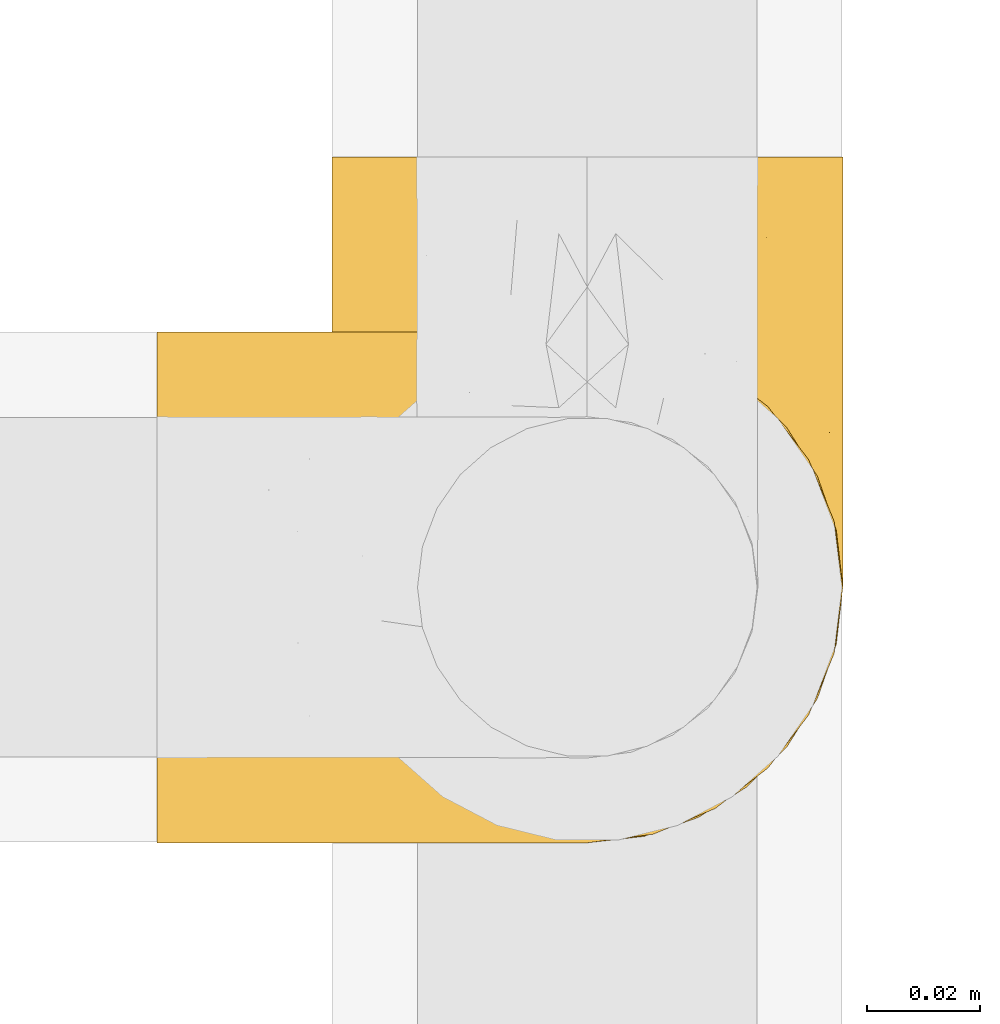
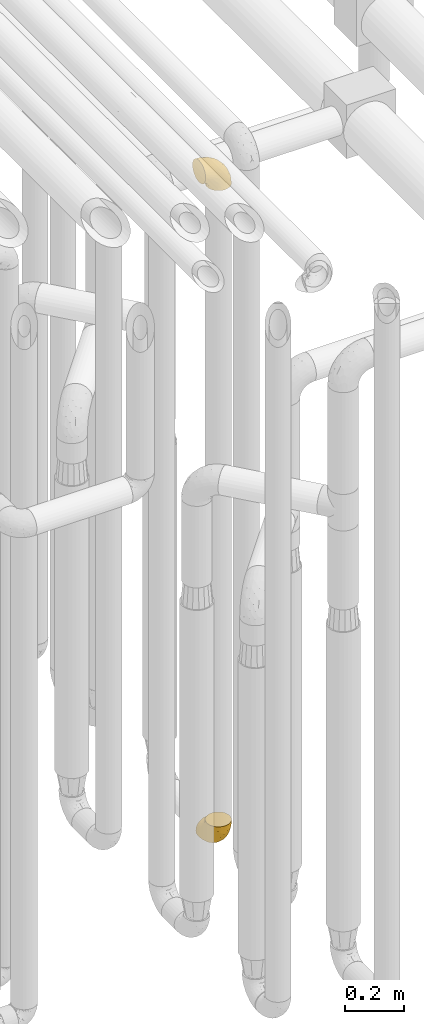
# One storey, part 205 of 827: 2 coverings.
"""IFC2X3 building model written with IfcOpenShell, lengths in millimetres."""

from ifc_helpers import new_model, entity, si_unit, converted_unit, derived_unit, direction, frame, origin, place, context, subcontext, project, spatial, faceted_brep, element, save


model = new_model("IFC2X3")

# Units and contexts
model_context = context("Model", 3, precision=0.01, world=origin(), true_north=direction((6.12303176911189e-17, 1.0)))
body_context = subcontext(model_context, "Body", "Model", "MODEL_VIEW")
ifc_project = project(units=[si_unit("LENGTHUNIT", "METRE", prefix="MILLI"), si_unit("AREAUNIT", "SQUARE_METRE"), si_unit("VOLUMEUNIT", "CUBIC_METRE"), converted_unit("PLANEANGLEUNIT", "DEGREE", entity("IfcRatioMeasure", 0.0174532925199433), si_unit("PLANEANGLEUNIT", "RADIAN"), dimensions=[0, 0, 0, 0, 0, 0, 0]), si_unit("MASSUNIT", "GRAM", prefix="KILO"), derived_unit("MASSDENSITYUNIT", [(si_unit("MASSUNIT", "GRAM", prefix="KILO"), 1), (si_unit("LENGTHUNIT", "METRE"), -3)]), derived_unit("MOMENTOFINERTIAUNIT", [(si_unit("LENGTHUNIT", "METRE"), 4)]), si_unit("TIMEUNIT", "SECOND"), si_unit("FREQUENCYUNIT", "HERTZ"), si_unit("THERMODYNAMICTEMPERATUREUNIT", "DEGREE_CELSIUS"), derived_unit("THERMALTRANSMITTANCEUNIT", [(si_unit("MASSUNIT", "GRAM", prefix="KILO"), 1), (si_unit("THERMODYNAMICTEMPERATUREUNIT", "KELVIN"), -1), (si_unit("TIMEUNIT", "SECOND"), -3)]), derived_unit("VOLUMETRICFLOWRATEUNIT", [(si_unit("LENGTHUNIT", "METRE"), 3), (si_unit("TIMEUNIT", "SECOND"), -1)]), derived_unit("MASSFLOWRATEUNIT", [(si_unit("MASSUNIT", "GRAM", prefix="KILO"), 1), (si_unit("TIMEUNIT", "SECOND"), -1)]), derived_unit("ROTATIONALFREQUENCYUNIT", [(si_unit("TIMEUNIT", "SECOND"), -1)]), si_unit("ELECTRICCURRENTUNIT", "AMPERE"), si_unit("ELECTRICVOLTAGEUNIT", "VOLT"), si_unit("POWERUNIT", "WATT"), si_unit("FORCEUNIT", "NEWTON", prefix="KILO"), si_unit("ILLUMINANCEUNIT", "LUX"), si_unit("LUMINOUSFLUXUNIT", "LUMEN"), si_unit("LUMINOUSINTENSITYUNIT", "CANDELA"), derived_unit("USERDEFINED", [(si_unit("MASSUNIT", "GRAM", prefix="KILO"), -1), (si_unit("LENGTHUNIT", "METRE"), -2), (si_unit("TIMEUNIT", "SECOND"), 3), (si_unit("LUMINOUSFLUXUNIT", "LUMEN"), 1)]), derived_unit("LINEARVELOCITYUNIT", [(si_unit("LENGTHUNIT", "METRE"), 1), (si_unit("TIMEUNIT", "SECOND"), -1)]), si_unit("PRESSUREUNIT", "PASCAL"), derived_unit("USERDEFINED", [(si_unit("LENGTHUNIT", "METRE"), -2), (si_unit("MASSUNIT", "GRAM", prefix="KILO"), 1), (si_unit("TIMEUNIT", "SECOND"), -2)]), derived_unit("LINEARFORCEUNIT", [(si_unit("MASSUNIT", "GRAM", prefix="KILO"), 1), (si_unit("LENGTHUNIT", "METRE"), 1), (si_unit("TIMEUNIT", "SECOND"), -2), (si_unit("LENGTHUNIT", "METRE"), -1)]), derived_unit("PLANARFORCEUNIT", [(si_unit("MASSUNIT", "GRAM", prefix="KILO"), 1), (si_unit("LENGTHUNIT", "METRE"), 1), (si_unit("TIMEUNIT", "SECOND"), -2), (si_unit("LENGTHUNIT", "METRE"), -2)])], contexts=[model_context])

# Site, building, storey
site_placement = place(None, origin())
site = spatial("IfcSite", under=ifc_project, at=site_placement, CompositionType="ELEMENT")
building_placement = place(site_placement, origin())
building = spatial("IfcBuilding", under=site, at=building_placement, CompositionType="ELEMENT")
storey_placement = place(building_placement, frame((0.0, 0.0, 28200.0)))
storey = spatial("IfcBuildingStorey", under=building, at=storey_placement, Name="08", CompositionType="ELEMENT", Elevation=28200.0)

# Coverings
covering_1_placement = place(storey_placement, frame((36928.29, 10884.43, 353.25)))
element("IfcCovering", 1, at=covering_1_placement, inside=storey, Name=":ADSK_", ObjectType=":ADSK_", PredefinedType="INSULATION", context=body_context, shape_type="Brep", body=[
    faceted_brep([(2.73, 36.69, 122.75), (6.07, 27.15, 122.75), (11.45, 18.59, 122.75), (18.6, 11.44, 122.75), (27.16, 6.06, 122.75), (36.7, 2.73, 122.75), (46.75, 1.6, 122.75), (56.8, 2.73, 122.75), (66.34, 6.07, 122.75), (74.9, 11.45, 122.75), (82.05, 18.6, 122.75), (87.43, 27.16, 122.75), (90.76, 36.7, 122.75), (91.9, 46.75, 122.75), (90.76, 56.8, 122.75), (87.42, 66.34, 122.75), (82.04, 74.9, 122.75), (74.89, 82.05, 122.75), (66.33, 87.43, 122.75), (56.79, 90.76, 122.75), (46.75, 91.9, 122.75), (36.69, 90.76, 122.75), (27.15, 87.42, 122.75), (18.59, 82.04, 122.75), (11.44, 74.89, 122.75), (6.06, 66.33, 122.75), (2.73, 56.79, 122.75), (1.6, 46.75, 122.75), (58.43, 122.75, 90.36), (69.32, 122.75, 85.85), (78.67, 122.75, 78.67), (85.85, 122.75, 69.32), (90.36, 122.75, 58.43), (91.9, 122.75, 46.75), (90.36, 122.75, 35.06), (85.85, 122.75, 24.17), (78.67, 122.75, 14.82), (69.32, 122.75, 7.64), (58.43, 122.75, 3.13), (46.75, 122.75, 1.6), (35.06, 122.75, 3.13), (24.17, 122.75, 7.64), (14.82, 122.75, 14.82), (7.64, 122.75, 24.17), (3.13, 122.75, 35.06), (1.6, 122.75, 46.75), (3.13, 122.75, 58.43), (7.64, 122.75, 69.32), (14.82, 122.75, 78.67), (24.17, 122.75, 85.85), (35.06, 122.75, 90.36), (46.75, 122.75, 91.9), (46.75, 24.73, 51.54), (38.29, 29.08, 47.17), (46.75, 38.13, 38.13), (46.75, 85.31, 7.52), (38.96, 93.59, 5.85), (46.75, 100.54, 5.11), (33.86, 63.54, 19.2), (31.42, 38.98, 38.98), (21.63, 50.71, 35.02), (30.84, 93.33, 8.21), (22.16, 75.2, 19.28), (20.56, 100.46, 12.19), (2.29, 41.6, 101.39), (7.18, 80.86, 34.43), (12.6, 94.87, 20.95), (14.0, 67.96, 30.74), (2.81, 52.16, 72.93), (6.65, 52.1, 56.64), (6.11, 36.74, 80.81), (16.62, 17.11, 93.43), (9.76, 23.24, 100.76), (12.46, 29.18, 74.27), (1.6, 52.53, 93.66), (1.6, 60.77, 81.33), (1.6, 69.01, 69.01), (2.46, 100.68, 40.87), (5.91, 103.79, 29.38), (36.97, 16.37, 67.05), (46.75, 7.52, 85.31), (33.09, 7.31, 93.68), (1.6, 93.66, 52.53), (1.6, 102.83, 50.71), (1.6, 112.01, 48.88), (25.62, 18.17, 72.77), (3.14, 71.97, 51.21), (23.92, 9.83, 101.18), (46.75, 5.11, 100.54), (13.58, 45.97, 48.74), (1.6, 48.88, 112.01), (1.6, 50.71, 102.83), (18.5, 22.83, 73.88), (46.75, 51.54, 24.73), (1.6, 81.33, 60.77), (4.96, 31.74, 103.08), (20.84, 32.48, 54.8), (46.75, 68.42, 16.13), (30.52, 25.33, 55.92), (46.75, 16.13, 68.42), (27.29, 92.29, 104.98), (36.89, 94.12, 108.58), (33.6, 100.97, 98.21), (2.54, 95.91, 61.56), (3.27, 107.9, 60.69), (16.85, 87.24, 100.0), (21.91, 95.46, 95.88), (13.5, 90.41, 90.81), (3.96, 74.17, 84.88), (3.52, 83.77, 73.29), (12.17, 76.72, 113.4), (18.93, 84.44, 109.8), (9.34, 76.42, 102.13), (3.12, 90.07, 67.29), (5.67, 99.69, 70.34), (2.51, 61.74, 95.15), (2.53, 58.16, 105.49), (8.35, 112.6, 71.5), (35.39, 110.45, 92.87), (46.75, 107.32, 96.03), (15.1, 108.48, 81.34), (5.27, 66.63, 107.44), (27.43, 115.23, 88.36), (24.89, 105.79, 90.43), (29.71, 89.6, 114.37), (5.07, 69.39, 98.41), (2.88, 66.99, 88.73), (9.69, 102.31, 76.89), (15.51, 99.54, 86.08), (2.27, 55.27, 112.64), (10.03, 82.03, 94.21), (46.75, 94.71, 112.22), (46.75, 96.03, 107.32), (8.83, 94.11, 79.95), (7.16, 84.21, 84.51), (46.75, 101.67, 101.67), (46.75, 112.22, 94.71), (78.39, 108.48, 81.34), (83.8, 102.31, 76.89), (77.97, 99.54, 86.08), (84.66, 94.11, 79.96), (58.1, 110.46, 92.87), (81.31, 76.74, 113.41), (91.9, 50.71, 102.83), (90.96, 58.17, 105.5), (91.22, 55.27, 112.64), (56.59, 94.12, 108.58), (66.18, 92.3, 104.98), (59.87, 100.98, 98.2), (88.42, 69.41, 98.4), (84.13, 76.44, 102.13), (88.22, 66.65, 107.44), (66.06, 115.24, 88.36), (91.9, 102.83, 50.71), (91.9, 112.01, 48.88), (83.44, 82.05, 94.22), (76.62, 87.25, 100.01), (85.14, 112.6, 71.5), (90.22, 107.9, 60.69), (91.9, 93.66, 52.53), (71.55, 95.48, 95.89), (63.77, 89.6, 114.37), (91.9, 60.77, 81.33), (91.9, 69.01, 69.01), (89.53, 74.17, 84.88), (91.9, 48.88, 112.01), (74.55, 84.45, 109.8), (90.95, 95.91, 61.56), (90.37, 90.07, 67.29), (91.9, 81.33, 60.77), (90.98, 61.75, 95.14), (89.97, 83.77, 73.29), (86.32, 84.21, 84.53), (91.9, 52.53, 93.66), (79.97, 90.42, 90.82), (90.61, 67.0, 88.73), (87.82, 99.69, 70.34), (68.6, 105.8, 90.43), (80.89, 94.87, 20.95), (86.31, 80.86, 34.43), (79.49, 67.95, 30.74), (71.33, 75.17, 19.29), (71.88, 50.65, 35.07), (90.35, 71.97, 51.21), (86.85, 52.08, 56.67), (72.67, 32.46, 54.85), (62.08, 38.98, 38.98), (87.58, 103.79, 29.38), (91.03, 100.68, 40.87), (59.62, 63.54, 19.2), (62.65, 93.32, 8.21), (54.53, 93.59, 5.85), (72.93, 100.44, 12.19), (90.68, 52.17, 72.93), (87.39, 36.75, 80.83), (91.2, 41.61, 101.39), (60.41, 7.31, 93.69), (76.88, 17.12, 93.43), (56.53, 16.37, 67.04), (83.74, 23.26, 100.76), (67.88, 18.17, 72.78), (62.99, 25.33, 55.93), (69.58, 9.84, 101.18), (81.04, 29.19, 74.27), (75.0, 22.84, 73.89), (88.53, 31.75, 103.09), (79.93, 45.96, 48.78), (55.21, 29.07, 47.19)], [[[0, 1, 2, 3, 4, 5, 6, 7, 8, 9, 10, 11, 12, 13, 14, 15, 16, 17, 18, 19, 20, 21, 22, 23, 24, 25, 26, 27]], [[28, 29, 30, 31, 32, 33, 34, 35, 36, 37, 38, 39, 40, 41, 42, 43, 44, 45, 46, 47, 48, 49, 50, 51]], [[52, 53, 54]], [[55, 56, 57]], [[58, 59, 60]], [[61, 62, 63]], [[27, 64, 0]], [[65, 66, 67]], [[41, 40, 61]], [[68, 69, 70]], [[66, 43, 42]], [[63, 42, 41]], [[71, 72, 73]], [[72, 2, 1]], [[68, 74, 75, 76]], [[45, 44, 77]], [[43, 78, 44]], [[79, 80, 81]], [[77, 82, 83, 84, 45]], [[79, 81, 85]], [[71, 2, 72]], [[65, 86, 77]], [[4, 81, 5]], [[66, 65, 78]], [[4, 3, 87]], [[81, 88, 5]], [[63, 66, 42]], [[68, 70, 64]], [[67, 60, 89]], [[71, 3, 2]], [[64, 27, 90, 91, 74]], [[92, 71, 73]], [[40, 57, 56]], [[59, 93, 54]], [[86, 76, 94, 82]], [[1, 0, 95]], [[58, 62, 61]], [[60, 96, 89]], [[85, 81, 87]], [[56, 97, 58]], [[65, 67, 69]], [[87, 81, 4]], [[67, 89, 69]], [[61, 63, 41]], [[95, 72, 1]], [[73, 72, 70]], [[69, 73, 70]], [[73, 89, 96]], [[3, 71, 87]], [[85, 87, 71]], [[58, 61, 56]], [[59, 58, 93]], [[76, 86, 68]], [[69, 89, 73]], [[68, 86, 69]], [[65, 69, 86]], [[68, 64, 74]], [[95, 64, 70]], [[98, 79, 85]], [[79, 52, 99, 80]], [[66, 62, 67]], [[62, 58, 60]], [[62, 60, 67]], [[59, 98, 96]], [[59, 96, 60]], [[96, 85, 92]], [[88, 81, 80]], [[88, 6, 5]], [[66, 63, 62]], [[64, 95, 0]], [[72, 95, 70]], [[77, 44, 78]], [[86, 82, 77]], [[40, 39, 57]], [[96, 98, 85]], [[40, 56, 61]], [[66, 78, 43]], [[77, 78, 65]], [[79, 98, 53]], [[96, 92, 73]], [[85, 71, 92]], [[97, 56, 55]], [[97, 93, 58]], [[53, 98, 59]], [[54, 53, 59]], [[79, 53, 52]], [[100, 101, 102]], [[46, 45, 84, 83]], [[103, 104, 82]], [[82, 104, 83]], [[105, 106, 107]], [[108, 109, 76]], [[110, 111, 112]], [[103, 113, 114]], [[115, 74, 116]], [[48, 47, 117]], [[118, 102, 119]], [[49, 48, 120]], [[74, 91, 116]], [[116, 121, 115]], [[49, 122, 50]], [[123, 106, 102]], [[124, 111, 22]], [[125, 126, 115]], [[23, 22, 111]], [[24, 110, 121]], [[120, 127, 128]], [[90, 26, 129]], [[27, 26, 90]], [[121, 125, 115]], [[24, 121, 25]], [[130, 105, 107]], [[129, 25, 116]], [[21, 20, 131]], [[120, 123, 122]], [[112, 105, 130]], [[50, 118, 51]], [[21, 124, 22]], [[101, 131, 132]], [[117, 120, 48]], [[24, 23, 110]], [[127, 114, 133]], [[75, 108, 76]], [[107, 134, 130]], [[133, 114, 113]], [[129, 116, 91]], [[25, 121, 116]], [[121, 112, 125]], [[75, 74, 115]], [[101, 135, 102]], [[131, 101, 21]], [[101, 100, 124]], [[128, 127, 133]], [[119, 136, 51, 118]], [[104, 47, 46]], [[83, 104, 46]], [[117, 104, 114]], [[101, 124, 21]], [[111, 124, 100]], [[102, 118, 123]], [[133, 134, 107]], [[111, 110, 23]], [[114, 104, 103]], [[94, 76, 109]], [[121, 110, 112]], [[122, 118, 50]], [[134, 109, 108]], [[133, 107, 128]], [[112, 108, 125]], [[126, 125, 108]], [[108, 75, 126]], [[75, 115, 126]], [[109, 134, 133]], [[130, 108, 112]], [[108, 130, 134]], [[105, 112, 111]], [[111, 100, 105]], [[106, 105, 100]], [[102, 106, 100]], [[128, 106, 123]], [[90, 129, 91]], [[25, 129, 26]], [[104, 117, 47]], [[117, 114, 127]], [[82, 94, 103]], [[113, 94, 109]], [[94, 113, 103]], [[133, 113, 109]], [[106, 128, 107]], [[123, 120, 128]], [[120, 122, 49]], [[118, 122, 123]], [[135, 101, 132]], [[135, 119, 102]], [[117, 127, 120]], [[30, 29, 137]], [[138, 139, 140]], [[51, 136, 119, 141]], [[142, 17, 16]], [[143, 144, 145]], [[146, 147, 148]], [[149, 150, 151]], [[152, 29, 28]], [[33, 32, 153, 154]], [[150, 155, 156]], [[157, 31, 30]], [[153, 158, 159]], [[29, 152, 137]], [[148, 141, 119]], [[156, 160, 147]], [[148, 135, 146]], [[137, 138, 157]], [[19, 161, 146]], [[162, 163, 164]], [[14, 13, 165]], [[153, 32, 158]], [[147, 161, 166]], [[18, 17, 166]], [[167, 168, 169]], [[166, 150, 156]], [[151, 150, 142]], [[151, 170, 149]], [[151, 16, 15]], [[171, 140, 172]], [[165, 143, 145]], [[173, 170, 144]], [[142, 166, 17]], [[19, 131, 20]], [[144, 170, 151]], [[18, 161, 19]], [[173, 144, 143]], [[140, 139, 174]], [[171, 164, 163]], [[164, 172, 155]], [[151, 15, 144]], [[145, 15, 14]], [[173, 162, 170]], [[149, 175, 164]], [[19, 146, 131]], [[132, 131, 146]], [[160, 148, 147]], [[159, 158, 167]], [[135, 132, 146]], [[158, 32, 31]], [[157, 158, 31]], [[167, 158, 176]], [[166, 161, 18]], [[146, 161, 147]], [[148, 177, 141]], [[171, 168, 140]], [[171, 163, 169]], [[151, 142, 16]], [[166, 142, 150]], [[152, 141, 177]], [[51, 141, 28]], [[138, 140, 176]], [[172, 140, 174]], [[175, 149, 170]], [[164, 150, 149]], [[170, 162, 175]], [[162, 164, 175]], [[155, 172, 174]], [[171, 172, 164]], [[155, 174, 156]], [[164, 155, 150]], [[160, 156, 174]], [[147, 166, 156]], [[139, 160, 174]], [[148, 160, 177]], [[15, 145, 144]], [[165, 145, 14]], [[137, 157, 30]], [[158, 157, 176]], [[168, 167, 176]], [[169, 159, 167]], [[140, 168, 176]], [[169, 168, 171]], [[137, 177, 139]], [[160, 139, 177]], [[141, 152, 28]], [[137, 152, 177]], [[148, 119, 135]], [[157, 138, 176]], [[139, 138, 137]], [[178, 179, 180]], [[181, 180, 182]], [[179, 183, 184]], [[185, 186, 182]], [[187, 188, 179]], [[188, 33, 154, 153, 159]], [[181, 189, 190]], [[35, 34, 187]], [[191, 38, 190]], [[192, 178, 181]], [[179, 184, 180]], [[192, 190, 37]], [[37, 190, 38]], [[36, 35, 178]], [[54, 93, 186]], [[35, 187, 178]], [[193, 194, 184]], [[195, 173, 143, 165, 13]], [[195, 193, 173]], [[193, 163, 162, 173]], [[13, 12, 195]], [[8, 7, 196]], [[9, 197, 10]], [[198, 80, 99, 52]], [[196, 7, 88]], [[197, 199, 10]], [[182, 189, 181]], [[200, 198, 201]], [[200, 196, 198]], [[9, 8, 202]], [[194, 199, 203]], [[192, 37, 36]], [[80, 196, 88]], [[183, 159, 169, 163]], [[188, 34, 33]], [[202, 200, 197]], [[185, 203, 204]], [[202, 8, 196]], [[10, 199, 11]], [[12, 11, 205]], [[38, 191, 57]], [[189, 97, 191]], [[203, 199, 197]], [[205, 199, 194]], [[204, 203, 197]], [[184, 203, 206]], [[200, 202, 196]], [[197, 9, 202]], [[207, 54, 186]], [[97, 55, 191]], [[194, 203, 184]], [[183, 163, 193]], [[184, 206, 180]], [[183, 193, 184]], [[205, 195, 12]], [[193, 195, 194]], [[80, 198, 196]], [[207, 186, 201]], [[182, 180, 206]], [[181, 178, 180]], [[185, 182, 206]], [[182, 186, 189]], [[203, 185, 206]], [[185, 200, 201]], [[7, 6, 88]], [[178, 192, 36]], [[190, 192, 181]], [[199, 205, 11]], [[195, 205, 194]], [[159, 183, 188]], [[179, 188, 183]], [[57, 191, 55]], [[57, 39, 38]], [[189, 191, 190]], [[188, 187, 34]], [[178, 187, 179]], [[186, 93, 189]], [[197, 200, 204]], [[185, 204, 200]], [[189, 93, 97]], [[207, 198, 52]], [[185, 201, 186]], [[198, 207, 201]], [[54, 207, 52]]]),
])
covering_2_placement = place(storey_placement, frame((36897.44, 10884.43, 3122.4)))
element("IfcCovering", 2, at=covering_2_placement, inside=storey, Name=":ADSK_", ObjectType=":ADSK_", PredefinedType="INSULATION", context=body_context, shape_type="Brep", body=[
    faceted_brep([(1.6, 2.73, 87.65), (1.6, 6.07, 97.19), (1.6, 11.45, 105.75), (1.6, 18.6, 112.9), (1.6, 27.16, 118.28), (1.6, 36.7, 121.61), (1.6, 46.75, 122.75), (1.6, 56.8, 121.61), (1.6, 66.34, 118.27), (1.6, 74.9, 112.89), (1.6, 82.05, 105.74), (1.6, 87.43, 97.18), (1.6, 90.76, 87.64), (1.6, 91.9, 77.6), (1.6, 90.76, 67.54), (1.6, 87.42, 58.0), (1.6, 82.04, 49.44), (1.6, 74.89, 42.29), (1.6, 66.33, 36.91), (1.6, 56.79, 33.58), (1.6, 46.75, 32.45), (1.6, 36.69, 33.58), (1.6, 27.15, 36.92), (1.6, 18.59, 42.3), (1.6, 11.44, 49.45), (1.6, 6.06, 58.01), (1.6, 2.73, 67.55), (1.6, 1.6, 77.6), (33.98, 58.43, 1.6), (38.49, 69.32, 1.6), (45.67, 78.67, 1.6), (55.02, 85.85, 1.6), (65.91, 90.36, 1.6), (77.6, 91.9, 1.6), (89.28, 90.36, 1.6), (100.17, 85.85, 1.6), (109.52, 78.67, 1.6), (116.7, 69.32, 1.6), (121.21, 58.43, 1.6), (122.75, 46.75, 1.6), (121.21, 35.06, 1.6), (116.7, 24.17, 1.6), (109.52, 14.82, 1.6), (100.17, 7.64, 1.6), (89.28, 3.13, 1.6), (77.6, 1.6, 1.6), (65.91, 3.13, 1.6), (55.02, 7.64, 1.6), (45.67, 14.82, 1.6), (38.49, 24.17, 1.6), (33.98, 35.06, 1.6), (32.45, 46.75, 1.6), (72.81, 46.75, 99.61), (77.17, 38.29, 95.26), (86.21, 46.75, 86.21), (116.82, 46.75, 39.03), (118.49, 38.96, 30.75), (119.23, 46.75, 23.8), (105.14, 33.86, 60.8), (85.37, 31.42, 85.37), (89.33, 21.63, 73.64), (116.14, 30.84, 31.01), (105.06, 22.16, 49.14), (112.15, 20.56, 23.88), (22.95, 2.29, 82.74), (89.91, 7.18, 43.48), (103.39, 12.6, 29.47), (93.6, 14.0, 56.38), (51.41, 2.81, 72.18), (67.71, 6.65, 72.24), (43.53, 6.11, 87.6), (30.91, 16.62, 107.24), (23.58, 9.76, 101.1), (50.07, 12.46, 95.16), (30.68, 1.6, 71.81), (43.01, 1.6, 63.57), (55.34, 1.6, 55.34), (83.48, 2.46, 23.66), (94.96, 5.91, 20.55), (57.29, 36.97, 107.97), (39.03, 46.75, 116.82), (30.66, 33.09, 117.03), (71.81, 1.6, 30.68), (73.63, 1.6, 21.51), (75.46, 1.6, 12.33), (51.57, 25.62, 106.17), (73.13, 3.14, 52.37), (23.16, 23.92, 114.51), (23.8, 46.75, 119.23), (75.6, 13.58, 78.37), (12.33, 1.6, 75.46), (21.51, 1.6, 73.63), (50.46, 18.5, 101.51), (99.61, 46.75, 72.81), (63.57, 1.6, 43.01), (21.26, 4.96, 92.6), (69.54, 20.84, 91.86), (108.21, 46.75, 55.92), (68.42, 30.52, 99.01), (55.92, 46.75, 108.21), (19.36, 27.29, 32.05), (15.76, 36.89, 30.22), (26.13, 33.6, 23.37), (62.78, 2.54, 28.43), (63.65, 3.27, 16.44), (24.34, 16.85, 37.1), (28.46, 21.91, 28.88), (33.53, 13.5, 33.93), (39.46, 3.96, 50.17), (51.05, 3.52, 40.57), (10.94, 12.17, 47.62), (14.55, 18.93, 39.9), (22.21, 9.34, 47.92), (57.05, 3.12, 34.27), (54.0, 5.67, 24.65), (29.19, 2.51, 62.6), (18.85, 2.53, 66.18), (52.84, 8.35, 11.74), (31.47, 35.39, 13.89), (28.31, 46.75, 17.02), (43.0, 15.1, 15.86), (16.9, 5.27, 57.71), (35.98, 27.43, 9.11), (33.91, 24.89, 18.55), (9.97, 29.71, 34.74), (25.93, 5.07, 54.95), (35.61, 2.88, 57.35), (47.45, 9.69, 22.03), (38.26, 15.51, 24.8), (11.7, 2.27, 69.07), (30.13, 10.03, 42.31), (12.12, 46.75, 29.63), (17.02, 46.75, 28.31), (44.39, 8.83, 30.23), (39.83, 7.16, 40.13), (22.67, 46.75, 22.67), (29.63, 46.75, 12.12), (43.0, 78.39, 15.86), (47.45, 83.8, 22.03), (38.26, 77.97, 24.8), (44.38, 84.66, 30.23), (31.47, 58.1, 13.88), (10.93, 81.31, 47.61), (21.51, 91.9, 73.63), (18.84, 90.96, 66.17), (11.7, 91.22, 69.07), (15.76, 56.59, 30.22), (19.36, 66.18, 32.04), (26.14, 59.87, 23.36), (25.94, 88.42, 54.93), (22.21, 84.13, 47.91), (16.9, 88.22, 57.69), (35.98, 66.06, 9.1), (73.63, 91.9, 21.51), (75.46, 91.9, 12.33), (30.12, 83.44, 42.29), (24.33, 76.62, 37.09), (52.84, 85.14, 11.74), (63.65, 90.22, 16.44), (71.81, 91.9, 30.68), (28.45, 71.55, 28.86), (9.97, 63.77, 34.74), (43.01, 91.9, 63.57), (55.34, 91.9, 55.34), (39.46, 89.53, 50.17), (12.33, 91.9, 75.46), (14.54, 74.55, 39.89), (62.78, 90.95, 28.43), (57.05, 90.37, 34.27), (63.57, 91.9, 43.01), (29.2, 90.98, 62.59), (51.05, 89.97, 40.57), (39.81, 86.32, 40.13), (30.68, 91.9, 71.81), (33.52, 79.97, 33.92), (35.61, 90.61, 57.34), (54.0, 87.82, 24.65), (33.91, 68.6, 18.54), (103.39, 80.89, 29.47), (89.91, 86.31, 43.48), (93.6, 79.49, 56.4), (105.05, 71.33, 49.17), (89.27, 71.88, 73.69), (73.13, 90.35, 52.37), (67.67, 86.85, 72.26), (69.49, 72.67, 91.88), (85.36, 62.08, 85.36), (94.96, 87.58, 20.55), (83.48, 91.03, 23.66), (105.14, 59.62, 60.8), (116.13, 62.65, 31.02), (118.49, 54.53, 30.75), (112.15, 72.93, 23.9), (51.41, 90.68, 72.17), (43.51, 87.39, 87.59), (22.95, 91.2, 82.74), (30.66, 60.41, 117.03), (30.91, 76.88, 107.23), (57.3, 56.53, 107.97), (23.58, 83.74, 101.08), (51.56, 67.88, 106.17), (68.41, 62.99, 99.01), (23.16, 69.58, 114.5), (50.07, 81.04, 95.15), (50.45, 75.0, 101.5), (21.25, 88.53, 92.59), (75.56, 79.93, 78.38), (77.16, 55.21, 95.27)], [[[0, 1, 2, 3, 4, 5, 6, 7, 8, 9, 10, 11, 12, 13, 14, 15, 16, 17, 18, 19, 20, 21, 22, 23, 24, 25, 26, 27]], [[28, 29, 30, 31, 32, 33, 34, 35, 36, 37, 38, 39, 40, 41, 42, 43, 44, 45, 46, 47, 48, 49, 50, 51]], [[52, 53, 54]], [[55, 56, 57]], [[58, 59, 60]], [[61, 62, 63]], [[27, 64, 0]], [[65, 66, 67]], [[41, 40, 61]], [[68, 69, 70]], [[66, 43, 42]], [[63, 42, 41]], [[71, 72, 73]], [[72, 2, 1]], [[68, 74, 75, 76]], [[45, 44, 77]], [[43, 78, 44]], [[79, 80, 81]], [[77, 82, 83, 84, 45]], [[79, 81, 85]], [[71, 2, 72]], [[65, 86, 77]], [[4, 81, 5]], [[66, 65, 78]], [[4, 3, 87]], [[81, 88, 5]], [[63, 66, 42]], [[68, 70, 64]], [[67, 60, 89]], [[71, 3, 2]], [[64, 27, 90, 91, 74]], [[92, 71, 73]], [[40, 57, 56]], [[59, 93, 54]], [[86, 76, 94, 82]], [[1, 0, 95]], [[58, 62, 61]], [[60, 96, 89]], [[85, 81, 87]], [[56, 97, 58]], [[65, 67, 69]], [[87, 81, 4]], [[67, 89, 69]], [[61, 63, 41]], [[95, 72, 1]], [[73, 72, 70]], [[69, 73, 70]], [[73, 89, 96]], [[3, 71, 87]], [[85, 87, 71]], [[58, 61, 56]], [[59, 58, 93]], [[76, 86, 68]], [[69, 89, 73]], [[68, 86, 69]], [[65, 69, 86]], [[68, 64, 74]], [[95, 64, 70]], [[98, 79, 85]], [[79, 52, 99, 80]], [[66, 62, 67]], [[62, 58, 60]], [[62, 60, 67]], [[59, 98, 96]], [[59, 96, 60]], [[96, 85, 92]], [[88, 81, 80]], [[88, 6, 5]], [[66, 63, 62]], [[64, 95, 0]], [[72, 95, 70]], [[77, 44, 78]], [[86, 82, 77]], [[40, 39, 57]], [[96, 98, 85]], [[40, 56, 61]], [[66, 78, 43]], [[77, 78, 65]], [[79, 98, 53]], [[96, 92, 73]], [[85, 71, 92]], [[97, 56, 55]], [[97, 93, 58]], [[53, 98, 59]], [[54, 53, 59]], [[79, 53, 52]], [[100, 101, 102]], [[46, 45, 84, 83]], [[103, 104, 82]], [[82, 104, 83]], [[105, 106, 107]], [[108, 109, 76]], [[110, 111, 112]], [[103, 113, 114]], [[115, 74, 116]], [[48, 47, 117]], [[118, 102, 119]], [[49, 48, 120]], [[74, 91, 116]], [[116, 121, 115]], [[49, 122, 50]], [[123, 106, 102]], [[124, 111, 22]], [[125, 126, 115]], [[23, 22, 111]], [[24, 110, 121]], [[120, 127, 128]], [[90, 26, 129]], [[27, 26, 90]], [[121, 125, 115]], [[24, 121, 25]], [[130, 105, 107]], [[129, 25, 116]], [[21, 20, 131]], [[120, 123, 122]], [[112, 105, 130]], [[50, 118, 51]], [[21, 124, 22]], [[101, 131, 132]], [[117, 120, 48]], [[24, 23, 110]], [[127, 114, 133]], [[75, 108, 76]], [[107, 134, 130]], [[133, 114, 113]], [[129, 116, 91]], [[25, 121, 116]], [[121, 112, 125]], [[75, 74, 115]], [[101, 135, 102]], [[131, 101, 21]], [[101, 100, 124]], [[128, 127, 133]], [[119, 136, 51, 118]], [[104, 47, 46]], [[83, 104, 46]], [[117, 104, 114]], [[101, 124, 21]], [[111, 124, 100]], [[102, 118, 123]], [[133, 134, 107]], [[111, 110, 23]], [[114, 104, 103]], [[94, 76, 109]], [[121, 110, 112]], [[122, 118, 50]], [[134, 109, 108]], [[133, 107, 128]], [[112, 108, 125]], [[126, 125, 108]], [[108, 75, 126]], [[75, 115, 126]], [[109, 134, 133]], [[130, 108, 112]], [[108, 130, 134]], [[105, 112, 111]], [[111, 100, 105]], [[106, 105, 100]], [[102, 106, 100]], [[128, 106, 123]], [[90, 129, 91]], [[25, 129, 26]], [[104, 117, 47]], [[117, 114, 127]], [[82, 94, 103]], [[113, 94, 109]], [[94, 113, 103]], [[133, 113, 109]], [[106, 128, 107]], [[123, 120, 128]], [[120, 122, 49]], [[118, 122, 123]], [[135, 101, 132]], [[135, 119, 102]], [[117, 127, 120]], [[30, 29, 137]], [[138, 139, 140]], [[51, 136, 119, 141]], [[142, 17, 16]], [[143, 144, 145]], [[146, 147, 148]], [[149, 150, 151]], [[152, 29, 28]], [[33, 32, 153, 154]], [[150, 155, 156]], [[157, 31, 30]], [[153, 158, 159]], [[29, 152, 137]], [[148, 141, 119]], [[156, 160, 147]], [[148, 135, 146]], [[137, 138, 157]], [[19, 161, 146]], [[162, 163, 164]], [[14, 13, 165]], [[153, 32, 158]], [[147, 161, 166]], [[18, 17, 166]], [[167, 168, 169]], [[166, 150, 156]], [[151, 150, 142]], [[151, 170, 149]], [[151, 16, 15]], [[171, 140, 172]], [[165, 143, 145]], [[173, 170, 144]], [[142, 166, 17]], [[19, 131, 20]], [[144, 170, 151]], [[18, 161, 19]], [[173, 144, 143]], [[140, 139, 174]], [[171, 164, 163]], [[164, 172, 155]], [[151, 15, 144]], [[145, 15, 14]], [[173, 162, 170]], [[149, 175, 164]], [[19, 146, 131]], [[132, 131, 146]], [[160, 148, 147]], [[159, 158, 167]], [[135, 132, 146]], [[158, 32, 31]], [[157, 158, 31]], [[167, 158, 176]], [[166, 161, 18]], [[146, 161, 147]], [[148, 177, 141]], [[171, 168, 140]], [[171, 163, 169]], [[151, 142, 16]], [[166, 142, 150]], [[152, 141, 177]], [[51, 141, 28]], [[138, 140, 176]], [[172, 140, 174]], [[175, 149, 170]], [[164, 150, 149]], [[170, 162, 175]], [[162, 164, 175]], [[155, 172, 174]], [[171, 172, 164]], [[155, 174, 156]], [[164, 155, 150]], [[160, 156, 174]], [[147, 166, 156]], [[139, 160, 174]], [[148, 160, 177]], [[15, 145, 144]], [[165, 145, 14]], [[137, 157, 30]], [[158, 157, 176]], [[168, 167, 176]], [[169, 159, 167]], [[140, 168, 176]], [[169, 168, 171]], [[137, 177, 139]], [[160, 139, 177]], [[141, 152, 28]], [[137, 152, 177]], [[148, 119, 135]], [[157, 138, 176]], [[139, 138, 137]], [[178, 179, 180]], [[181, 180, 182]], [[179, 183, 184]], [[185, 186, 182]], [[187, 188, 179]], [[188, 33, 154, 153, 159]], [[181, 189, 190]], [[35, 34, 187]], [[191, 38, 190]], [[192, 178, 181]], [[179, 184, 180]], [[192, 190, 37]], [[37, 190, 38]], [[36, 35, 178]], [[54, 93, 186]], [[35, 187, 178]], [[193, 194, 184]], [[195, 173, 143, 165, 13]], [[195, 193, 173]], [[193, 163, 162, 173]], [[13, 12, 195]], [[8, 7, 196]], [[9, 197, 10]], [[198, 80, 99, 52]], [[196, 7, 88]], [[197, 199, 10]], [[182, 189, 181]], [[200, 198, 201]], [[200, 196, 198]], [[9, 8, 202]], [[194, 199, 203]], [[192, 37, 36]], [[80, 196, 88]], [[183, 159, 169, 163]], [[188, 34, 33]], [[202, 200, 197]], [[185, 203, 204]], [[202, 8, 196]], [[10, 199, 11]], [[12, 11, 205]], [[38, 191, 57]], [[189, 97, 191]], [[203, 199, 197]], [[205, 199, 194]], [[204, 203, 197]], [[184, 203, 206]], [[200, 202, 196]], [[197, 9, 202]], [[207, 54, 186]], [[97, 55, 191]], [[194, 203, 184]], [[183, 163, 193]], [[184, 206, 180]], [[183, 193, 184]], [[205, 195, 12]], [[193, 195, 194]], [[80, 198, 196]], [[207, 186, 201]], [[182, 180, 206]], [[181, 178, 180]], [[185, 182, 206]], [[182, 186, 189]], [[203, 185, 206]], [[185, 200, 201]], [[7, 6, 88]], [[178, 192, 36]], [[190, 192, 181]], [[199, 205, 11]], [[195, 205, 194]], [[159, 183, 188]], [[179, 188, 183]], [[57, 191, 55]], [[57, 39, 38]], [[189, 191, 190]], [[188, 187, 34]], [[178, 187, 179]], [[186, 93, 189]], [[197, 200, 204]], [[185, 204, 200]], [[189, 93, 97]], [[207, 198, 52]], [[185, 201, 186]], [[198, 207, 201]], [[54, 207, 52]]]),
])

save(model, "model.ifc")
